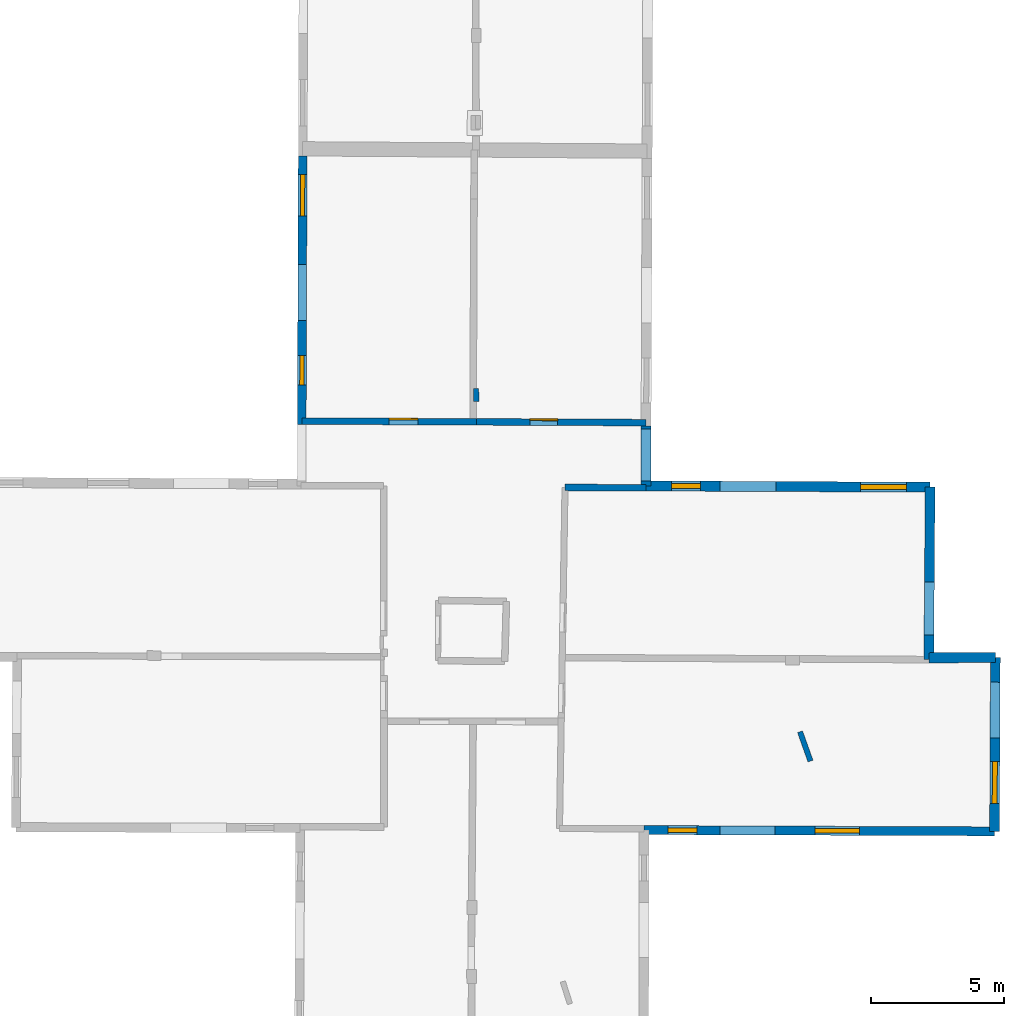
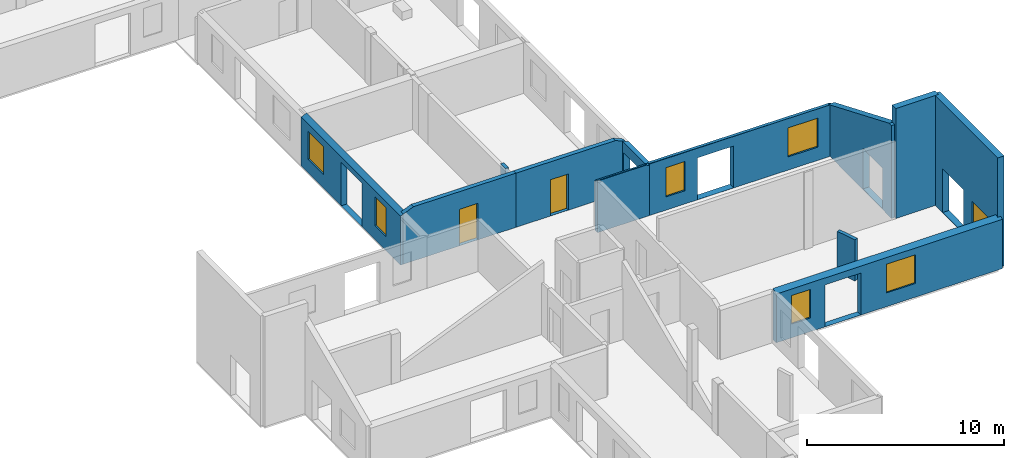
# One storey, part 4 of 10: 12 walls, 7 windows, 2 doors, 15 openings.
"""IFC2X3 building model written with IfcOpenShell, lengths in metres."""

from ifc_helpers import new_model, entity, si_unit, converted_unit, derived_unit, direction, frame, frame_2d, origin, origin_2d_with_axis, place, context, subcontext, project, spatial, polyline, rectangle, outline, extrude, clip, halfspace, source, transform, mapped, material, layer, layer_set, layer_usage, type_object, type_shapes, element, fill, save


model = new_model("IFC2X3")

# Units and contexts
model_context = context("Model", 3, precision=1e-05, world=origin(), true_north=direction((0.0, 1.0)))
body_context = subcontext(model_context, "Body", "Model", "MODEL_VIEW")
ifc_project = project(units=[si_unit("LENGTHUNIT", "METRE"), si_unit("AREAUNIT", "SQUARE_METRE"), si_unit("VOLUMEUNIT", "CUBIC_METRE"), converted_unit("PLANEANGLEUNIT", "DEGREE", entity("IfcRatioMeasure", 0.0174532925199433), si_unit("PLANEANGLEUNIT", "RADIAN"), dimensions=[0, 0, 0, 0, 0, 0, 0]), si_unit("MASSUNIT", "GRAM", prefix="KILO"), derived_unit("MASSDENSITYUNIT", [(si_unit("MASSUNIT", "GRAM", prefix="KILO"), 1), (si_unit("LENGTHUNIT", "METRE"), -3)]), derived_unit("MOMENTOFINERTIAUNIT", [(si_unit("LENGTHUNIT", "METRE"), 4)]), si_unit("TIMEUNIT", "SECOND"), si_unit("FREQUENCYUNIT", "HERTZ"), si_unit("THERMODYNAMICTEMPERATUREUNIT", "DEGREE_CELSIUS"), derived_unit("THERMALTRANSMITTANCEUNIT", [(si_unit("MASSUNIT", "GRAM", prefix="KILO"), 1), (si_unit("THERMODYNAMICTEMPERATUREUNIT", "KELVIN"), -1), (si_unit("TIMEUNIT", "SECOND"), -3)]), derived_unit("VOLUMETRICFLOWRATEUNIT", [(si_unit("LENGTHUNIT", "METRE"), 3), (si_unit("TIMEUNIT", "SECOND"), -1)]), si_unit("ELECTRICCURRENTUNIT", "AMPERE"), si_unit("ELECTRICVOLTAGEUNIT", "VOLT"), si_unit("POWERUNIT", "WATT"), si_unit("FORCEUNIT", "NEWTON", prefix="KILO"), si_unit("ILLUMINANCEUNIT", "LUX"), si_unit("LUMINOUSFLUXUNIT", "LUMEN"), si_unit("LUMINOUSINTENSITYUNIT", "CANDELA"), derived_unit("USERDEFINED", [(si_unit("MASSUNIT", "GRAM", prefix="KILO"), -1), (si_unit("LENGTHUNIT", "METRE"), -2), (si_unit("TIMEUNIT", "SECOND"), 3), (si_unit("LUMINOUSFLUXUNIT", "LUMEN"), 1)]), derived_unit("LINEARVELOCITYUNIT", [(si_unit("LENGTHUNIT", "METRE"), 1), (si_unit("TIMEUNIT", "SECOND"), -1)]), si_unit("PRESSUREUNIT", "PASCAL"), derived_unit("USERDEFINED", [(si_unit("LENGTHUNIT", "METRE"), -2), (si_unit("MASSUNIT", "GRAM", prefix="KILO"), 1), (si_unit("TIMEUNIT", "SECOND"), -2)]), derived_unit("LINEARFORCEUNIT", [(si_unit("MASSUNIT", "GRAM", prefix="KILO"), 1), (si_unit("LENGTHUNIT", "METRE"), 1), (si_unit("TIMEUNIT", "SECOND"), -2), (si_unit("LENGTHUNIT", "METRE"), -1)]), derived_unit("PLANARFORCEUNIT", [(si_unit("MASSUNIT", "GRAM", prefix="KILO"), 1), (si_unit("LENGTHUNIT", "METRE"), 1), (si_unit("TIMEUNIT", "SECOND"), -2), (si_unit("LENGTHUNIT", "METRE"), -2)])], contexts=[model_context])

# Site, building, storey
placement = place(None, origin())
site = spatial("IfcSite", under=ifc_project, at=placement, CompositionType="ELEMENT")
building = spatial("IfcBuilding", under=site, at=placement, CompositionType="ELEMENT")
storey_placement = place(placement, frame((0.0, 0.0, 15.2695512771606)))
storey = spatial("IfcBuildingStorey", under=building, at=storey_placement, Name="Level 6", CompositionType="ELEMENT", Elevation=15.2695512771606)

# Wall
ifc_material_1 = material(Name="Default wall")
ifc_layer_1 = layer(ifc_material_1, 0.25)
ifc_layer_set_1 = layer_set([ifc_layer_1], Name="wall_thickness_0.2500")
ifc_layer_usage_1 = layer_usage(ifc_layer_set_1, "AXIS2", "POSITIVE", -0.125)
wall_type_1 = type_object("IfcWallType", Name="wall_thickness_0.2500", PredefinedType="STANDARD", material=ifc_layer_set_1)
wall_1_placement = place(storey_placement, frame((9.66698385118976, 25.8311106914742, 0.0), z_axis=(0.0, 0.0, 1.0), x_axis=(0.999990260295804, -0.00441353753022589, 0.0)))
element("IfcWallStandardCase", 1, at=wall_1_placement, inside=storey, type_object=wall_type_1, material=ifc_layer_usage_1, Name="Wall:212", ObjectType="Wall", context=body_context, shape_type="Clipping", body=[
    clip(clip(extrude(outline(polyline([(3.04931177336928, -0.125), (3.04931177336928, 0.125), (0.0, 0.125), (0.0, -0.125), (3.04931177336928, -0.125)])), origin(), (0.0, 0.0, 1.0), 3.19044971466064), halfspace(frame((14.7417453117729, -6.52927746612305, 5.89042703244326), z_axis=(0.0016210286814823, 0.389132780048993, 0.921180249330909), x_axis=(-0.999985323669658, 0.00539292544238605, -0.000518459702406835)), False)), halfspace(frame((2.92262984287933, 51.4189072919637, 3.16730048752112), z_axis=(0.390500081105043, -0.000180313815728746, 0.920602875372374), x_axis=(-0.680738985635771, -0.673268937307264, 0.288623234499112)), False)),
])

# Wall, opening, door
wall_2_placement = place(storey_placement, frame((-0.256806151712943, 28.3329035332125, 0.0), z_axis=(0.0, 0.0, 1.0), x_axis=(0.999989741425162, -0.00452957442123878, 0.0)))
wall_2 = element("IfcWallStandardCase", 2, at=wall_2_placement, inside=storey, type_object=wall_type_1, material=ifc_layer_usage_1, Name="Wall:223", ObjectType="Wall", context=body_context, shape_type="Clipping", body=[
    clip(extrude(outline(polyline([(6.58370811487134, -0.125), (6.58370811487134, 0.125), (0.0, 0.125), (0.0, -0.125), (6.58370811487134, -0.125)])), origin(), (0.0, 0.0, 1.0), 3.35544872283936), halfspace(frame((-1.22118849772953, 47.5058557507428, 2.60439273833051), z_axis=(-0.389900615191682, -0.000351657832584267, 0.920856876289642), x_axis=(0.920854986017514, -0.00137593096214202, 0.38990281037801)), False)),
])
opening_1_placement = place(wall_2_placement, frame((3.29173814344799, -0.125, 0.0124492645263672)))
opening_1 = element("IfcOpeningElement", 3, at=opening_1_placement, cuts=wall_2, Name="Opening : 1085 x 2250 : 200", ObjectType="Opening", context=body_context, shape_type="SweptSolid", body=[
    extrude(rectangle(XDim=1.085, YDim=2.25, at=frame_2d((1.125, 0.5425), x_axis=(0.0, 1.0))), frame((0.0, 0.0, 0.0), z_axis=(0.0, 1.0, 0.0), x_axis=(0.0, 0.0, 1.0)), (0.0, 0.0, 1.0), 0.25),
])
ifc_material_2 = material(Name="Door Panel")
door_style_1 = type_object("IfcDoorStyle", Name="Door : 1085 x 2250mm", ConstructionType="NOTDEFINED", OperationType="SINGLE_SWING_RIGHT", ParameterTakesPrecedence=False, Sizeable=False, material=ifc_material_2)
shared_shape_1 = source(origin(), body_context, "Body", "SweptSolid", [
    extrude(rectangle(XDim=0.0625, YDim=1.085, at=origin_2d_with_axis()), frame((0.5425, 0.21875, 0.0), z_axis=(0.0, 0.0, 1.0), x_axis=(0.0, 1.0, 0.0)), (0.0, 0.0, 1.0), 2.25),
])
type_shapes(door_style_1, [shared_shape_1])
door_1_placement = place(opening_1_placement, origin())
door_1 = element("IfcDoor", 4, at=door_1_placement, inside=storey, type_object=door_style_1, Name="Door : 1085 x 2250mm : 34", ObjectType="Door : 1085 x 2250mm", OverallHeight=2.25, OverallWidth=1.085, context=body_context, shape_type="MappedRepresentation", body=[
    mapped(shared_shape_1, transform((0.0, 0.0, 0.0), scale=1.0)),
])
fill(opening_1, door_1)

wall_3_placement = place(storey_placement, frame((6.32683442369599, 28.3030821373385, 0.0), z_axis=(0.0, 0.0, 1.0), x_axis=(0.999989741092388, -0.00452964788694423, 0.0)))
wall_3 = element("IfcWallStandardCase", 5, at=wall_3_placement, inside=storey, type_object=wall_type_1, material=ifc_layer_usage_1, Name="Wall:224", ObjectType="Wall", context=body_context, shape_type="Clipping", body=[
    clip(extrude(outline(polyline([(6.3991678594704, -0.125), (6.3991678594704, 0.125), (0.0, 0.125), (0.0, -0.125), (6.3991678594704, -0.125)])), origin(), (0.0, 0.0, 1.0), 3.35544872283936), halfspace(frame((6.26797181727703, 48.9624299109962, 3.16730048752112), z_axis=(0.390500099409215, -0.000134972257566336, 0.920602875372374), x_axis=(-0.680660806769046, -0.673347974405346, 0.288623234499112)), False)),
])
opening_2_placement = place(wall_3_placement, frame((2.01512207902719, -0.125, 0.0104484558105469)))
opening_2 = element("IfcOpeningElement", 6, at=opening_2_placement, cuts=wall_3, Name="Opening : 1050 x 2235 : 201", ObjectType="Opening", context=body_context, shape_type="SweptSolid", body=[
    extrude(rectangle(XDim=1.05, YDim=2.235, at=frame_2d((1.1175, 0.525), x_axis=(0.0, 1.0))), frame((0.0, 0.0, 0.0), z_axis=(0.0, 1.0, 0.0), x_axis=(0.0, 0.0, 1.0)), (0.0, 0.0, 1.0), 0.25),
])
door_style_2 = type_object("IfcDoorStyle", Name="Door : 1050 x 2235mm", ConstructionType="NOTDEFINED", OperationType="SINGLE_SWING_RIGHT", ParameterTakesPrecedence=False, Sizeable=False, material=ifc_material_2)
shared_shape_2 = source(origin(), body_context, "Body", "SweptSolid", [
    extrude(rectangle(XDim=0.0625, YDim=1.05, at=origin_2d_with_axis()), frame((0.525, 0.21875, 0.0), z_axis=(0.0, 0.0, 1.0), x_axis=(0.0, 1.0, 0.0)), (0.0, 0.0, 1.0), 2.235),
])
type_shapes(door_style_2, [shared_shape_2])
door_2_placement = place(opening_2_placement, origin())
door_2 = element("IfcDoor", 7, at=door_2_placement, inside=storey, type_object=door_style_2, Name="Door : 1050 x 2235mm : 35", ObjectType="Door : 1050 x 2235mm", OverallHeight=2.235, OverallWidth=1.05, context=body_context, shape_type="MappedRepresentation", body=[
    mapped(shared_shape_2, transform((0.0, 0.0, 0.0), scale=1.0)),
])
fill(opening_2, door_2)

# Wall, openings, windows
ifc_layer_2 = layer(ifc_material_1, 0.330000013113022)
ifc_layer_set_2 = layer_set([ifc_layer_2], Name="wall_thickness_0.3300")
ifc_layer_usage_2 = layer_usage(ifc_layer_set_2, "AXIS2", "POSITIVE", -0.165000006556511)
wall_type_2 = type_object("IfcWallType", Name="wall_thickness_0.3300", PredefinedType="STANDARD", material=ifc_layer_set_2)
wall_4_placement = place(storey_placement, frame((-0.224308415751115, 38.3277688586787, 0.0), z_axis=(0.0, 0.0, 1.0), x_axis=(-0.00325150114330051, -0.999994713856186, 0.0)))
wall_4 = element("IfcWallStandardCase", 8, at=wall_4_placement, inside=storey, type_object=wall_type_2, material=ifc_layer_usage_2, Name="Wall:183", ObjectType="Wall", context=body_context, shape_type="Clipping", body=[
    clip(extrude(outline(polyline([(10.1199150981098, -0.165000006556511), (10.1199150981098, 0.165000006556511), (0.0, 0.165000006556511), (0.0, -0.165000006556511), (10.1199150981098, -0.165000006556511)])), origin(), (0.0, 0.0, 1.0), 3.19044971466064), halfspace(frame((-37.512459572713, -1.16047033657192, 2.60439273833051), z_axis=(-0.000146667681620914, -0.389900746188918, 0.920856876289642), x_axis=(0.00255285865572728, 0.920852475357488, 0.389902810378011)), False)),
])
opening_3_placement = place(wall_4_placement, frame((4.08371604525118, -0.165000006556511, 0.011448860168457)))
element("IfcOpeningElement", 9, at=opening_3_placement, cuts=wall_4, Name="Opening : 2120 x 2675 : 162", ObjectType="Opening", context=body_context, shape_type="SweptSolid", body=[
    extrude(rectangle(XDim=2.12, YDim=2.675, at=frame_2d((1.3375, 1.06), x_axis=(0.0, 1.0))), frame((0.0, 0.0, 0.0), z_axis=(0.0, 1.0, 0.0), x_axis=(0.0, 0.0, 1.0)), (0.0, 0.0, 1.0), 0.330000013113022),
])
opening_4_placement = place(wall_4_placement, frame((0.692691650055125, -0.165000006556511, 0.84544849395752)))
opening_4 = element("IfcOpeningElement", 10, at=opening_4_placement, cuts=wall_4, Name="Opening : 1570 x 1720 : 163", ObjectType="Opening", context=body_context, shape_type="SweptSolid", body=[
    extrude(rectangle(XDim=1.57, YDim=1.72, at=frame_2d((0.86, 0.785), x_axis=(0.0, 1.0))), frame((0.0, 0.0, 0.0), z_axis=(0.0, 1.0, 0.0), x_axis=(0.0, 0.0, 1.0)), (0.0, 0.0, 1.0), 0.330000013113022),
])
opening_5_placement = place(wall_4_placement, frame((7.51371731577523, -0.165000006556511, 0.881449699401855)))
opening_5 = element("IfcOpeningElement", 11, at=opening_5_placement, cuts=wall_4, Name="Opening : 1130 x 1790 : 164", ObjectType="Opening", context=body_context, shape_type="SweptSolid", body=[
    extrude(rectangle(XDim=1.13, YDim=1.79, at=frame_2d((0.895, 0.565), x_axis=(0.0, 1.0))), frame((0.0, 0.0, 0.0), z_axis=(0.0, 1.0, 0.0), x_axis=(0.0, 0.0, 1.0)), (0.0, 0.0, 1.0), 0.330000013113022),
])
ifc_material_3 = material(Name="Window Default")
window_style_1 = type_object("IfcWindowStyle", Name="Window : 1570 x 1720mm", ConstructionType="NOTDEFINED", OperationType="NOTDEFINED", ParameterTakesPrecedence=False, Sizeable=False, material=ifc_material_3)
shared_shape_3 = source(origin(), body_context, "Body", "SweptSolid", [
    extrude(rectangle(XDim=0.165000006556511, YDim=1.57, at=origin_2d_with_axis()), frame((0.785, 0.165000006556511, 0.0), z_axis=(0.0, 0.0, 1.0), x_axis=(0.0, 1.0, 0.0)), (0.0, 0.0, 1.0), 1.72),
])
type_shapes(window_style_1, [shared_shape_3])
window_1_placement = place(opening_4_placement, origin())
window_1 = element("IfcWindow", 12, at=window_1_placement, inside=storey, type_object=window_style_1, Name="Window : 1570 x 1720mm : 89", ObjectType="Window : 1570 x 1720mm", OverallHeight=1.72, OverallWidth=1.57, context=body_context, shape_type="MappedRepresentation", body=[
    mapped(shared_shape_3, transform((0.0, 0.0, 0.0), scale=1.0)),
])
fill(opening_4, window_1)
window_style_2 = type_object("IfcWindowStyle", Name="Window : 1130 x 1790mm", ConstructionType="NOTDEFINED", OperationType="NOTDEFINED", ParameterTakesPrecedence=False, Sizeable=False, material=ifc_material_3)
shared_shape_4 = source(origin(), body_context, "Body", "SweptSolid", [
    extrude(rectangle(XDim=0.165000006556511, YDim=1.13, at=origin_2d_with_axis()), frame((0.565, 0.165000006556511, 0.0), z_axis=(0.0, 0.0, 1.0), x_axis=(0.0, 1.0, 0.0)), (0.0, 0.0, 1.0), 1.79),
])
type_shapes(window_style_2, [shared_shape_4])
window_2_placement = place(opening_5_placement, origin())
window_2 = element("IfcWindow", 13, at=window_2_placement, inside=storey, type_object=window_style_2, Name="Window : 1130 x 1790mm : 90", ObjectType="Window : 1130 x 1790mm", OverallHeight=1.79, OverallWidth=1.13, context=body_context, shape_type="MappedRepresentation", body=[
    mapped(shared_shape_4, transform((0.0, 0.0, 0.0), scale=1.0)),
])
fill(opening_5, window_2)

# Walls
ifc_layer_3 = layer(ifc_material_1, 0.2)
ifc_layer_set_3 = layer_set([ifc_layer_3], Name="wall_thickness_0.2000")
ifc_layer_usage_3 = layer_usage(ifc_layer_set_3, "AXIS2", "POSITIVE", -0.1)
wall_type_3 = type_object("IfcWallType", Name="wall_thickness_0.2000", PredefinedType="STANDARD", material=ifc_layer_set_3)
wall_5_placement = place(storey_placement, frame((6.31374102203472, 29.5687951563414, 0.0), z_axis=(0.0, 0.0, 1.0), x_axis=(0.00863123065328615, -0.999962750234932, 0.0)))
element("IfcWallStandardCase", 14, at=wall_5_placement, inside=storey, type_object=wall_type_3, material=ifc_layer_usage_3, Name="Wall:145", ObjectType="Wall", context=body_context, shape_type="Clipping", body=[
    clip(extrude(outline(polyline([(0.495000204388392, -0.1), (0.495000204388392, 0.1), (0.0, 0.1), (0.0, -0.1), (0.495000204388392, -0.1)])), origin(), (0.0, 0.0, 1.0), 3.13044834136963), halfspace(frame((-47.6099202463119, 6.91397323048951, 3.16730048752112), z_axis=(0.0052741844805664, 0.39046450393625, 0.920602875372374), x_axis=(0.664331740200609, -0.689463535996866, 0.288623234499112)), False)),
])
wall_6_placement = place(storey_placement, frame((18.9235738985595, 15.5128982145456, 0.0), z_axis=(0.0, 0.0, 1.0), x_axis=(-0.336182041721892, 0.941797024216843, 0.0)))
element("IfcWallStandardCase", 15, at=wall_6_placement, inside=storey, type_object=wall_type_3, material=ifc_layer_usage_3, Name="Wall:227", ObjectType="Wall", context=body_context, shape_type="Clipping", body=[
    clip(extrude(outline(polyline([(1.17499973282594, -0.1), (1.17499973282594, 0.1), (0.0, 0.1), (0.0, -0.1), (1.17499973282594, -0.1)])), origin(), (0.0, 0.0, 1.0), 2.54944896697998), halfspace(frame((14.2505801613359, 27.7829323221569, 5.79555813666937), z_axis=(-0.365026563129544, 0.134858149314533, 0.921177989192801), x_axis=(-0.345401477349068, -0.938454874056843, 0.000518463148508191)), False)),
])

# Wall, opening
ifc_layer_4 = layer(ifc_material_1, 0.379999995231628)
ifc_layer_set_4 = layer_set([ifc_layer_4], Name="wall_thickness_0.3800")
ifc_layer_usage_4 = layer_usage(ifc_layer_set_4, "AXIS2", "POSITIVE", -0.189999997615814)
wall_type_4 = type_object("IfcWallType", Name="wall_thickness_0.3800", PredefinedType="STANDARD", material=ifc_layer_set_4)
wall_7_placement = place(storey_placement, frame((12.7254427851927, 28.1490972040821, 0.0), z_axis=(0.0, 0.0, 1.0), x_axis=(-0.00393620410755697, -0.999992253118605, 0.0)))
wall_7 = element("IfcWallStandardCase", 16, at=wall_7_placement, inside=storey, type_object=wall_type_4, material=ifc_layer_usage_4, Name="Wall:143", ObjectType="Wall", context=body_context, shape_type="Clipping", body=[
    clip(extrude(outline(polyline([(2.26267850892665, -0.189999997615814), (2.26267850892665, 0.189999997615814), (0.0, 0.189999997615814), (0.0, -0.189999997615814), (2.26267850892665, -0.189999997615814)])), origin(), (0.0, 0.0, 1.0), 3.19044971466064), halfspace(frame((-49.0874990789503, -0.102137486328771, 3.16730048752112), z_axis=(0.000366714154587847, 0.390499950546535, 0.920602875372374), x_axis=(0.672943918312193, -0.681060284639989, 0.288623234499112)), False)),
])
opening_6_placement = place(wall_7_placement, frame((0.113627319972275, -0.189999997615814, 0.00544929504394531)))
element("IfcOpeningElement", 17, at=opening_6_placement, cuts=wall_7, Name="Opening : 1955 x 2530 : 135", ObjectType="Opening", context=body_context, shape_type="SweptSolid", body=[
    extrude(rectangle(XDim=1.955, YDim=2.53, at=frame_2d((1.265, 0.9775), x_axis=(0.0, 1.0))), frame((0.0, 0.0, 0.0), z_axis=(0.0, 1.0, 0.0), x_axis=(0.0, 0.0, 1.0)), (0.0, 0.0, 1.0), 0.379999995231628),
])

# Wall, openings, windows
wall_8_placement = place(storey_placement, frame((12.7165358534161, 25.8864426238748, 0.0), z_axis=(0.0, 0.0, 1.0), x_axis=(0.999990470447254, -0.00436566314308871, 0.0)))
wall_8 = element("IfcWallStandardCase", 18, at=wall_8_placement, inside=storey, type_object=wall_type_4, material=ifc_layer_usage_4, Name="Wall:181", ObjectType="Wall", context=body_context, shape_type="Clipping", body=[
    clip(extrude(outline(polyline([(10.7171030905029, -0.189999997615814), (10.7171030905029, 0.189999997615814), (0.0, 0.189999997615814), (0.0, -0.189999997615814), (10.7171030905029, -0.189999997615814)])), origin(), (0.0, 0.0, 1.0), 3.19044971466064), halfspace(frame((11.6921513259284, -6.59862793935307, 5.89042703244326), z_axis=(0.00163965835246373, 0.389132701996545, 0.921180249330909), x_axis=(-0.999985064338186, 0.00544079958194479, -0.000518459702406836)), False)),
])
opening_7_placement = place(wall_8_placement, frame((2.80078117605167, -0.189999997615814, 0.00544929504394531)))
element("IfcOpeningElement", 19, at=opening_7_placement, cuts=wall_8, Name="Opening : 2110 x 2595 : 156", ObjectType="Opening", context=body_context, shape_type="SweptSolid", body=[
    extrude(rectangle(XDim=2.11, YDim=2.595, at=frame_2d((1.2975, 1.055), x_axis=(0.0, 1.0))), frame((0.0, 0.0, 0.0), z_axis=(0.0, 1.0, 0.0), x_axis=(0.0, 0.0, 1.0)), (0.0, 0.0, 1.0), 0.379999995231628),
])
opening_8_placement = place(wall_8_placement, frame((0.960781604824685, -0.189999997615814, 0.820448875427246)))
opening_8 = element("IfcOpeningElement", 20, at=opening_8_placement, cuts=wall_8, Name="Opening : 1100 x 1810 : 157", ObjectType="Opening", context=body_context, shape_type="SweptSolid", body=[
    extrude(rectangle(XDim=1.1, YDim=1.81, at=frame_2d((0.905, 0.55), x_axis=(0.0, 1.0))), frame((0.0, 0.0, 0.0), z_axis=(0.0, 1.0, 0.0), x_axis=(0.0, 0.0, 1.0)), (0.0, 0.0, 1.0), 0.379999995231628),
])
opening_9_placement = place(wall_8_placement, frame((8.08578179066342, -0.189999997615814, 0.820448875427246)))
opening_9 = element("IfcOpeningElement", 21, at=opening_9_placement, cuts=wall_8, Name="Opening : 1745 x 1795 : 158", ObjectType="Opening", context=body_context, shape_type="SweptSolid", body=[
    extrude(rectangle(XDim=1.745, YDim=1.795, at=frame_2d((0.8975, 0.8725), x_axis=(0.0, 1.0))), frame((0.0, 0.0, 0.0), z_axis=(0.0, 1.0, 0.0), x_axis=(0.0, 0.0, 1.0)), (0.0, 0.0, 1.0), 0.379999995231628),
])
window_style_3 = type_object("IfcWindowStyle", Name="Window : 1100 x 1810mm", ConstructionType="NOTDEFINED", OperationType="NOTDEFINED", ParameterTakesPrecedence=False, Sizeable=False, material=ifc_material_3)
shared_shape_5 = source(origin(), body_context, "Body", "SweptSolid", [
    extrude(rectangle(XDim=0.189999997615814, YDim=1.1, at=origin_2d_with_axis()), frame((0.55, 0.189999997615814, 0.0), z_axis=(0.0, 0.0, 1.0), x_axis=(0.0, 1.0, 0.0)), (0.0, 0.0, 1.0), 1.81),
])
type_shapes(window_style_3, [shared_shape_5])
window_3_placement = place(opening_8_placement, origin())
window_3 = element("IfcWindow", 22, at=window_3_placement, inside=storey, type_object=window_style_3, Name="Window : 1100 x 1810mm : 85", ObjectType="Window : 1100 x 1810mm", OverallHeight=1.81, OverallWidth=1.1, context=body_context, shape_type="MappedRepresentation", body=[
    mapped(shared_shape_5, transform((0.0, 0.0, 0.0), scale=1.0)),
])
fill(opening_8, window_3)
window_style_4 = type_object("IfcWindowStyle", Name="Window : 1745 x 1795mm", ConstructionType="NOTDEFINED", OperationType="NOTDEFINED", ParameterTakesPrecedence=False, Sizeable=False, material=ifc_material_3)
shared_shape_6 = source(origin(), body_context, "Body", "SweptSolid", [
    extrude(rectangle(XDim=0.189999997615814, YDim=1.745, at=origin_2d_with_axis()), frame((0.8725, 0.189999997615814, 0.0), z_axis=(0.0, 0.0, 1.0), x_axis=(0.0, 1.0, 0.0)), (0.0, 0.0, 1.0), 1.795),
])
type_shapes(window_style_4, [shared_shape_6])
window_4_placement = place(opening_9_placement, origin())
window_4 = element("IfcWindow", 23, at=window_4_placement, inside=storey, type_object=window_style_4, Name="Window : 1745 x 1795mm : 86", ObjectType="Window : 1745 x 1795mm", OverallHeight=1.795, OverallWidth=1.745, context=body_context, shape_type="MappedRepresentation", body=[
    mapped(shared_shape_6, transform((0.0, 0.0, 0.0), scale=1.0)),
])
fill(opening_9, window_4)

# Wall
wall_9_placement = place(storey_placement, frame((23.3854179461784, 19.4072621447533, 0.0), z_axis=(0.0, 0.0, 1.0), x_axis=(0.999996245847441, 0.0027401260964797, 0.0)))
element("IfcWallStandardCase", 24, at=wall_9_placement, inside=storey, type_object=wall_type_4, material=ifc_layer_usage_4, Name="Wall:222", ObjectType="Wall", context=body_context, shape_type="SweptSolid", body=[
    extrude(outline(polyline([(2.50867450278567, -0.189999997615814), (2.50867450278567, 0.189999997615814), (0.0, 0.189999997615814), (0.0, -0.189999997615814), (2.50867450278567, -0.189999997615814)])), origin(), (0.0, 0.0, 1.0), 6.8064489364624),
])

# Wall, openings, windows
ifc_layer_5 = layer(ifc_material_1, 0.340000003576279)
ifc_layer_set_5 = layer_set([ifc_layer_5], Name="wall_thickness_0.3400")
ifc_layer_usage_5 = layer_usage(ifc_layer_set_5, "AXIS2", "POSITIVE", -0.170000001788139)
wall_type_5 = type_object("IfcWallType", Name="wall_thickness_0.3400", PredefinedType="STANDARD", material=ifc_layer_set_5)
wall_10_placement = place(storey_placement, frame((12.6481416912149, 12.9119708278779, 0.0), z_axis=(0.0, 0.0, 1.0), x_axis=(0.99999327325133, -0.00366789477650773, 0.0)))
wall_10 = element("IfcWallStandardCase", 25, at=wall_10_placement, inside=storey, type_object=wall_type_5, material=ifc_layer_usage_5, Name="Wall:190", ObjectType="Wall", context=body_context, shape_type="Clipping", body=[
    clip(extrude(outline(polyline([(13.2142803259102, -0.170000001788139), (13.2142803259102, 0.170000001788139), (0.0, 0.170000001788139), (0.0, -0.170000001788139), (13.2142803259102, -0.170000001788139)])), origin(), (0.0, 0.0, 1.0), 5.08544826507568), halfspace(frame((-24.7055826080852, 6.59138532408732, 5.79555813666937), z_axis=(-0.00286635634267259, -0.389130949974459, 0.921177989192801), x_axis=(0.999981024065501, -0.00613862402136778, 0.000518463148508191)), False)),
])
opening_10_placement = place(wall_10_placement, frame((2.85571971392197, -0.170000001788139, 0.00544929504394531)))
element("IfcOpeningElement", 26, at=opening_10_placement, cuts=wall_10, Name="Opening : 2090 x 2595 : 170", ObjectType="Opening", context=body_context, shape_type="SweptSolid", body=[
    extrude(rectangle(XDim=2.09, YDim=2.595, at=frame_2d((1.2975, 1.045), x_axis=(0.0, 1.0))), frame((0.0, 0.0, 0.0), z_axis=(0.0, 1.0, 0.0), x_axis=(0.0, 0.0, 1.0)), (0.0, 0.0, 1.0), 0.340000003576279),
])
opening_11_placement = place(wall_10_placement, frame((6.45072127328849, -0.170000001788139, 0.850449562072754)))
opening_11 = element("IfcOpeningElement", 27, at=opening_11_placement, cuts=wall_10, Name="Opening : 1680 x 1775 : 171", ObjectType="Opening", context=body_context, shape_type="SweptSolid", body=[
    extrude(rectangle(XDim=1.68, YDim=1.775, at=frame_2d((0.8875, 0.84), x_axis=(0.0, 1.0))), frame((0.0, 0.0, 0.0), z_axis=(0.0, 1.0, 0.0), x_axis=(0.0, 0.0, 1.0)), (0.0, 0.0, 1.0), 0.340000003576279),
])
opening_12_placement = place(wall_10_placement, frame((0.895719840304337, -0.170000001788139, 0.850449562072754)))
opening_12 = element("IfcOpeningElement", 28, at=opening_12_placement, cuts=wall_10, Name="Opening : 1095 x 1765 : 172", ObjectType="Opening", context=body_context, shape_type="SweptSolid", body=[
    extrude(rectangle(XDim=1.095, YDim=1.765, at=frame_2d((0.8825, 0.5475), x_axis=(0.0, 1.0))), frame((0.0, 0.0, 0.0), z_axis=(0.0, 1.0, 0.0), x_axis=(0.0, 0.0, 1.0)), (0.0, 0.0, 1.0), 0.340000003576279),
])
window_style_5 = type_object("IfcWindowStyle", Name="Window : 1680 x 1775mm", ConstructionType="NOTDEFINED", OperationType="NOTDEFINED", ParameterTakesPrecedence=False, Sizeable=False, material=ifc_material_3)
shared_shape_7 = source(origin(), body_context, "Body", "SweptSolid", [
    extrude(rectangle(XDim=0.170000001788139, YDim=1.68, at=origin_2d_with_axis()), frame((0.84, 0.170000001788139, 0.0), z_axis=(0.0, 0.0, 1.0), x_axis=(0.0, 1.0, 0.0)), (0.0, 0.0, 1.0), 1.775),
])
type_shapes(window_style_5, [shared_shape_7])
window_5_placement = place(opening_11_placement, origin())
window_5 = element("IfcWindow", 29, at=window_5_placement, inside=storey, type_object=window_style_5, Name="Window : 1680 x 1775mm : 94", ObjectType="Window : 1680 x 1775mm", OverallHeight=1.775, OverallWidth=1.68, context=body_context, shape_type="MappedRepresentation", body=[
    mapped(shared_shape_7, transform((0.0, 0.0, 0.0), scale=1.0)),
])
fill(opening_11, window_5)
window_style_6 = type_object("IfcWindowStyle", Name="Window : 1095 x 1765mm", ConstructionType="NOTDEFINED", OperationType="NOTDEFINED", ParameterTakesPrecedence=False, Sizeable=False, material=ifc_material_3)
shared_shape_8 = source(origin(), body_context, "Body", "SweptSolid", [
    extrude(rectangle(XDim=0.170000001788139, YDim=1.095, at=origin_2d_with_axis()), frame((0.5475, 0.170000001788139, 0.0), z_axis=(0.0, 0.0, 1.0), x_axis=(0.0, 1.0, 0.0)), (0.0, 0.0, 1.0), 1.765),
])
type_shapes(window_style_6, [shared_shape_8])
window_6_placement = place(opening_12_placement, origin())
window_6 = element("IfcWindow", 30, at=window_6_placement, inside=storey, type_object=window_style_6, Name="Window : 1095 x 1765mm : 95", ObjectType="Window : 1095 x 1765mm", OverallHeight=1.765, OverallWidth=1.095, context=body_context, shape_type="MappedRepresentation", body=[
    mapped(shared_shape_8, transform((0.0, 0.0, 0.0), scale=1.0)),
])
fill(opening_12, window_6)

# Wall, openings, window
ifc_layer_6 = layer(ifc_material_1, 0.370000004768372)
ifc_layer_set_6 = layer_set([ifc_layer_6], Name="wall_thickness_0.3700")
ifc_layer_usage_6 = layer_usage(ifc_layer_set_6, "AXIS2", "POSITIVE", -0.185000002384186)
wall_type_6 = type_object("IfcWallType", Name="wall_thickness_0.3700", PredefinedType="STANDARD", material=ifc_layer_set_6)
wall_11_placement = place(storey_placement, frame((25.8940827511231, 19.4141368572622, 0.0), z_axis=(0.0, 0.0, 1.0), x_axis=(-0.00484675783956753, -0.999988254400243, 0.0)))
wall_11 = element("IfcWallStandardCase", 31, at=wall_11_placement, inside=storey, type_object=wall_type_6, material=ifc_layer_usage_6, Name="Wall:147", ObjectType="Wall", context=body_context, shape_type="SweptSolid", body=[
    extrude(outline(polyline([(6.55071418724519, -0.185000002384186), (6.55071418724519, 0.185000002384186), (0.0, 0.185000002384186), (0.0, -0.185000002384186), (6.55071418724519, -0.185000002384186)])), origin(), (0.0, 0.0, 1.0), 6.8064489364624),
])
opening_13_placement = place(wall_11_placement, frame((0.928570950932153, -0.185000002384186, 0.011448860168457)))
element("IfcOpeningElement", 32, at=opening_13_placement, cuts=wall_11, Name="Opening : 2110 x 2690 : 141", ObjectType="Opening", context=body_context, shape_type="SweptSolid", body=[
    extrude(rectangle(XDim=2.11, YDim=2.69, at=frame_2d((1.345, 1.055), x_axis=(0.0, 1.0))), frame((0.0, 0.0, 0.0), z_axis=(0.0, 1.0, 0.0), x_axis=(0.0, 0.0, 1.0)), (0.0, 0.0, 1.0), 0.370000004768372),
])
opening_14_placement = place(wall_11_placement, frame((3.90970795260875, -0.185000002384186, 0.86044979095459)))
opening_14 = element("IfcOpeningElement", 33, at=opening_14_placement, cuts=wall_11, Name="Opening : 1585 x 1670 : 142", ObjectType="Opening", context=body_context, shape_type="SweptSolid", body=[
    extrude(rectangle(XDim=1.585, YDim=1.67, at=frame_2d((0.835, 0.7925), x_axis=(0.0, 1.0))), frame((0.0, 0.0, 0.0), z_axis=(0.0, 1.0, 0.0), x_axis=(0.0, 0.0, 1.0)), (0.0, 0.0, 1.0), 0.370000004768372),
])
window_style_7 = type_object("IfcWindowStyle", Name="Window : 1585 x 1670mm", ConstructionType="NOTDEFINED", OperationType="NOTDEFINED", ParameterTakesPrecedence=False, Sizeable=False, material=ifc_material_3)
shared_shape_9 = source(origin(), body_context, "Body", "SweptSolid", [
    extrude(rectangle(XDim=0.185000002384186, YDim=1.585, at=origin_2d_with_axis()), frame((0.7925, 0.185000002384186, 0.0), z_axis=(0.0, 0.0, 1.0), x_axis=(0.0, 1.0, 0.0)), (0.0, 0.0, 1.0), 1.67),
])
type_shapes(window_style_7, [shared_shape_9])
window_7_placement = place(opening_14_placement, origin())
window_7 = element("IfcWindow", 34, at=window_7_placement, inside=storey, type_object=window_style_7, Name="Window : 1585 x 1670mm : 81", ObjectType="Window : 1585 x 1670mm", OverallHeight=1.67, OverallWidth=1.585, context=body_context, shape_type="MappedRepresentation", body=[
    mapped(shared_shape_9, transform((0.0, 0.0, 0.0), scale=1.0)),
])
fill(opening_14, window_7)

# Wall, opening
wall_12_placement = place(storey_placement, frame((23.4335392615656, 25.8396540315884, 0.0), z_axis=(0.0, 0.0, 1.0), x_axis=(-0.00748089721510717, -0.999972017696924, 0.0)))
wall_12 = element("IfcWallStandardCase", 35, at=wall_12_placement, inside=storey, type_object=wall_type_6, material=ifc_layer_usage_6, Name="Wall:177", ObjectType="Wall", context=body_context, shape_type="Clipping", body=[
    clip(extrude(outline(polyline([(6.5020549588299, -0.185000002384186), (6.5020549588299, 0.185000002384186), (0.0, 0.185000002384186), (0.0, -0.185000002384186), (6.5020549588299, -0.185000002384186)])), origin(), (0.0, 0.0, 1.0), 5.75544834136963), halfspace(frame((6.5955570543635, 0.995597653531765, 5.89042703244326), z_axis=(-0.389135921728451, 0.000427391148361966, 0.921180249330909), x_axis=(-0.00232553476551939, -0.999997161539767, -0.000518459702406836)), False)),
])
opening_15_placement = place(wall_12_placement, frame((3.57367967349436, -0.185000002384186, 0.0504493713378906)))
element("IfcOpeningElement", 36, at=opening_15_placement, cuts=wall_12, Name="Opening : 2005 x 2505 : 155", ObjectType="Opening", context=body_context, shape_type="SweptSolid", body=[
    extrude(rectangle(XDim=2.005, YDim=2.505, at=frame_2d((1.2525, 1.0025), x_axis=(0.0, 1.0))), frame((0.0, 0.0, 0.0), z_axis=(0.0, 1.0, 0.0), x_axis=(0.0, 0.0, 1.0)), (0.0, 0.0, 1.0), 0.370000004768372),
])

save(model, "model.ifc")
